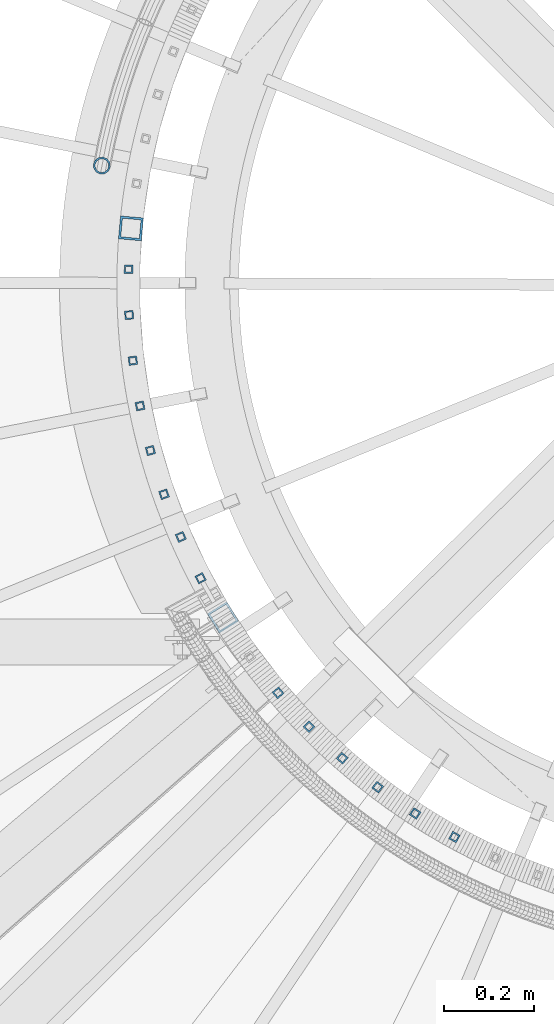
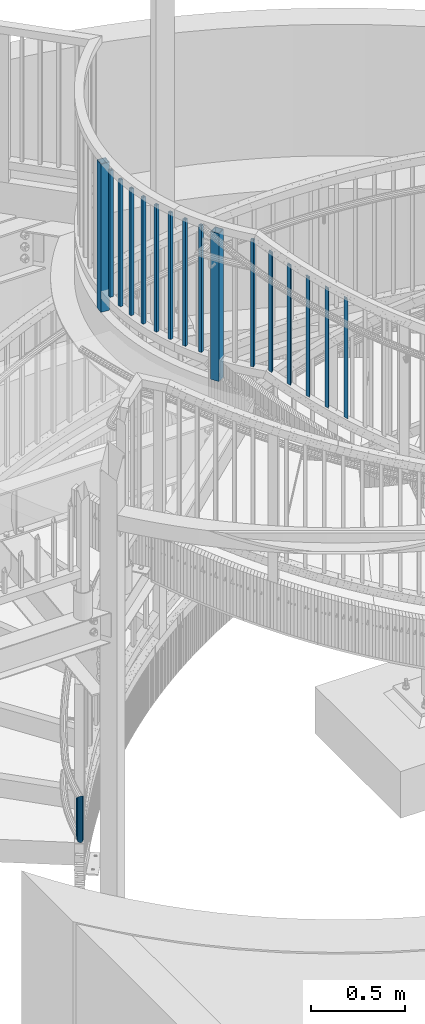
# One storey, part 258 of 975: 17 columns.
"""IFC2X3 building model written with IfcOpenShell, lengths in millimetres."""

from ifc_helpers import new_model, si_unit, frame, origin_with_axes, place, context, subcontext, project, spatial, faceted_brep, material, type_object, element, save


model = new_model("IFC2X3")

# Units and contexts
model_context = context("Model", 3, precision=1e-05, world=origin_with_axes())
body_context = subcontext(model_context, "Body", "Model", "MODEL_VIEW")
ifc_project = project(units=[si_unit("LENGTHUNIT", "METRE", prefix="MILLI"), si_unit("AREAUNIT", "SQUARE_METRE"), si_unit("VOLUMEUNIT", "CUBIC_METRE"), si_unit("MASSUNIT", "GRAM", prefix="KILO"), si_unit("TIMEUNIT", "SECOND"), si_unit("PLANEANGLEUNIT", "RADIAN"), si_unit("SOLIDANGLEUNIT", "STERADIAN"), si_unit("THERMODYNAMICTEMPERATUREUNIT", "DEGREE_CELSIUS"), si_unit("LUMINOUSINTENSITYUNIT", "LUMEN")], contexts=[model_context])

# Site, building, storey
site_placement = place(None, origin_with_axes())
site = spatial("IfcSite", under=ifc_project, at=site_placement, CompositionType="ELEMENT")
building_placement = place(site_placement, origin_with_axes())
building = spatial("IfcBuilding", under=site, at=building_placement, Name="Undefined", CompositionType="ELEMENT")
storey_placement = place(building_placement, origin_with_axes())
storey = spatial("IfcBuildingStorey", under=building, at=storey_placement, Name="Undefined", CompositionType="ELEMENT", Elevation=0.0)

# Columns
ifc_material = material()
column_type_1 = type_object("IfcColumnType", Name="HSS3/4X3/4X.120_TUBES", PredefinedType="NOTDEFINED")
for number, where, z_axis, x_axis, name in (
    (1, (33338.0118651315, 3439.09067871105, 4279.9), (-0.999675195412586, 0.0254853620105182, 0.0), (0.0, 0.0, 1.0), "PICKET"),
    (2, (33339.116408192, 3337.53503253503, 4279.9), (-0.998884410589074, -0.0472221799805738, 0.0), (0.0, 0.0, 1.0), "PICKET"),
    (3, (33347.5974477952, 3236.3281095807, 4279.9), (-0.992812511867641, -0.119680057984045, 0.0), (0.0, 0.0, 1.0), "PICKET"),
    (4, (33363.4101445628, 3136.00499207486, 4279.9), (-0.981491601442438, -0.191505186086326, 0.0), (0.0, 0.0, 1.0), "PICKET"),
    (5, (33386.4708966174, 3037.09608953945, 4279.9), (-0.964981533340402, -0.262317823092534, 0.0), (0.0, 0.0, 1.0), "PICKET"),
    (6, (33416.6577814516, 2940.12433452441, 4279.9), (-0.943369596226937, -0.331743583079804, 0.0), (0.0, 0.0, 1.0), "PICKET"),
    (7, (33453.8112006605, 2845.60241787445, 4279.9), (-0.916770052714921, -0.399415410875797, 0.0), (0.0, 0.0, 1.0), "PICKET"),
    (8, (33497.7347236588, 2754.03007809531, 4279.9), (-0.885323534790213, -0.46497552488982, 0.0), (0.0, 0.0, 1.0), "PICKET"),
    (9, (33669.5281021066, 2499.83083556219, 4279.9), (-0.762453802431629, -0.647042656366294, 0.0), (0.0, 0.0, 1.0), "PICKET"),
):
    element("IfcColumn", number, at=place(storey_placement, frame(where, z_axis=z_axis, x_axis=x_axis)), inside=storey, type_object=column_type_1, material=ifc_material, Name=name, ObjectType="HSS3/4X3/4X.120_TUBES", context=body_context, shape_type="Brep", body=[
        faceted_brep([(0.0, 6.34999999998763, -6.34999999998763), (0.0, -6.35000000000582, -6.34999999998763), (825.49997943247, -6.35000000000582, -6.34999999998763), (825.49997943247, 6.34999999998763, -6.34999999998763), (0.0, -6.34999999998763, 6.34999999998763), (825.49997943247, -6.34999999998763, 6.34999999998763), (0.0, 6.35000000000946, 6.34999999998763), (825.49997943247, 6.35000000000946, 6.34999999998763), (0.0, 9.52499999997963, -9.52499999997963), (0.0, 9.52500000000873, 9.5249999999869), (825.49997943247, 9.52500000000873, 9.5249999999869), (825.49997943247, 9.52499999997963, -9.52499999997963), (0.0, -9.52499999997963, 9.52499999998327), (825.49997943247, -9.52499999997963, 9.52499999998327), (0.0, -9.52500000000873, -9.5249999999869), (825.49997943247, -9.52500000000873, -9.5249999999869)], [[[0, 1, 2, 3]], [[1, 4, 5, 2]], [[4, 6, 7, 5]], [[6, 0, 3, 7]], [[8, 9, 10, 11]], [[9, 12, 13, 10]], [[12, 14, 15, 13]], [[14, 8, 11, 15]], [[13, 15, 11, 10], [5, 7, 3, 2]], [[14, 12, 9, 8], [6, 4, 1, 0]]]),
    ])
for number, where, z_axis, x_axis, name in (
    (10, (33738.0146394789, 2424.8350790669, 4191.955686045), (-0.71342169087057, -0.700734964872866, 0.0), (0.0, 0.0, 1.0), "PICKET"),
    (11, (33811.7696069116, 2355.01406451793, 4125.280686045), (-0.660617710250523, -0.750722479284692, 0.0), (0.0, 0.0, 1.0), "PICKET"),
    (12, (33890.4030610031, 2290.73693646062, 4058.605686045), (-0.604321034827168, -0.796740915772135, 0.0), (0.0, 0.0, 1.0), "PICKET"),
    (13, (33973.4992657341, 2232.34352884534, 3992.724436045), (-0.544829307083477, -0.838546973128481, 0.0), (0.0, 0.0, 1.0), "PICKET"),
    (14, (34060.6188904695, 2180.14256832157, 3926.049436045), (-0.482457061020897, -0.875919622037935, 0.0), (0.0, 0.0, 1.0), "PICKET"),
):
    element("IfcColumn", number, at=place(storey_placement, frame(where, z_axis=z_axis, x_axis=x_axis)), inside=storey, type_object=column_type_1, material=ifc_material, Name=name, ObjectType="HSS3/4X3/4X.120_TUBES", context=body_context, shape_type="Brep", body=[
        faceted_brep([(81.3030822565961, 6.34999999999491, -6.34999999997672), (73.0243810963957, -6.34999999999854, -6.35000000000582), (849.31820965341, -6.34999999999854, -6.35000000000582), (857.556470281766, 6.34999999999491, -6.34999999997672), (73.0243810963952, -6.34999999999127, 6.34999999998399), (849.318209653409, -6.34999999999127, 6.34999999998399), (81.3030822565956, 6.35000000000218, 6.34999999999854), (857.556470281765, 6.35000000000218, 6.34999999999854), (83.3727575466464, 9.52499999999054, -9.52499999997235), (83.3727575466455, 9.52500000000509, 9.52500000000146), (859.616035438854, 9.52500000000509, 9.52500000000146), (859.616035438854, 9.52499999999054, -9.52499999997235), (70.9547058063449, -9.5249999999869, 9.52499999997235), (847.25864449632, -9.5249999999869, 9.52499999997235), (70.9547058063458, -9.52500000000146, -9.52499999999418), (847.258644496321, -9.52500000000146, -9.52499999999418)], [[[0, 1, 2, 3]], [[1, 4, 5, 2]], [[4, 6, 7, 5]], [[6, 0, 3, 7]], [[8, 9, 10, 11]], [[9, 12, 13, 10]], [[12, 14, 15, 13]], [[14, 8, 11, 15]], [[13, 15, 11, 10], [5, 7, 3, 2]], [[14, 12, 9, 8], [6, 4, 1, 0]]]),
    ])
column_type_2 = type_object("IfcColumnType", Name="HSS2X2X.188_TUBES", PredefinedType="NOTDEFINED")
for number, where, z_axis, x_axis, name in (
    (15, (33343.2053867211, 3529.72810575534, 4140.2), (-0.995915974724204, 0.0902849449749974, 0.0), (0.0, 0.0, 1.0), "HANDRAIL"),
    (16, (33547.4569280127, 2667.02838416945, 4140.2), (-0.8497086989124, -0.527252431945644, 0.0), (0.0, 0.0, 1.0), "HANDRAIL"),
):
    element("IfcColumn", number, at=place(storey_placement, frame(where, z_axis=z_axis, x_axis=x_axis)), inside=storey, type_object=column_type_2, material=ifc_material, Name=name, ObjectType="HSS2X2X.188_TUBES", context=body_context, shape_type="Brep", body=[
        faceted_brep([(0.0, 20.6374999999753, -20.6375000000298), (0.0, -20.6375000000153, -20.6375000000153), (965.200000000001, -20.6374999999025, -20.6375000000808), (965.200000000001, 20.637500000008, -20.637500000008), (0.0, -20.6374999999825, 20.6375000000335), (965.200000000001, -20.6375000000007, 20.6375000000116), (0.0, 20.6375000000116, 20.6375000000189), (965.200000000001, 20.6374999999061, 20.6375000000844), (0.0, 25.3999999999724, -25.4000000000342), (0.0, 25.400000000016, 25.4000000000196), (965.200000000001, 25.399999999885, 25.400000000107), (965.200000000001, 25.4000000000124, -25.4000000000124), (0.0, -25.399999999976, 25.4000000000378), (965.200000000001, -25.4000000000015, 25.4000000000124), (0.0, -25.400000000016, -25.4000000000196), (965.200000000001, -25.3999999998778, -25.4000000001033)], [[[0, 1, 2, 3]], [[1, 4, 5, 2]], [[4, 6, 7, 5]], [[6, 0, 3, 7]], [[8, 9, 10, 11]], [[9, 12, 13, 10]], [[12, 14, 15, 13]], [[14, 8, 11, 15]], [[13, 15, 11, 10], [5, 7, 3, 2]], [[14, 12, 9, 8], [6, 4, 1, 0]]]),
    ])
column_type_3 = type_object("IfcColumnType", PredefinedType="NOTDEFINED")
column_placement = place(storey_placement, frame((33278.7955524752, 3668.84646025861, 609.6), z_axis=(0.16657944603268, 0.986028036193417, 0.0), x_axis=(0.0, 0.0, 1.0)))
element("IfcColumn", 17, at=column_placement, inside=storey, type_object=column_type_3, material=ifc_material, Name="HANDRAIL", context=body_context, shape_type="Brep", body=[
    faceted_brep([(18.916988254354, -15.3669999999365, 1.09139364212751e-11), (26.61830844902, -13.3082123798886, 7.68350000001374), (278.182504532853, -13.3082123798886, 7.68350000001374), (285.883950497071, -15.3669999999365, 1.09139364212751e-11), (32.2917065065848, -7.68349999994098, 13.3082123799686), (272.508762868242, -7.68349999994098, 13.3082123799686), (34.4169999991835, 4.00177668780088e-11, 15.3670000000093), (270.383000000335, 4.00177668780088e-11, 15.3670000000093), (32.4247182517954, 7.6835000000101, 13.3082123799577), (272.374812372886, 7.6835000000101, 13.3082123799577), (26.8486915497282, 13.3082123799359, 7.68349999999737), (277.950495469197, 13.3082123799359, 7.68349999999737), (19.1830117447753, 15.3669999999511, -1.09139364212751e-11), (285.61604950636, 15.3669999999511, -1.09139364212751e-11), (11.4816915501094, 13.3082123799031, -7.68350000001374), (293.317495470578, 13.3082123799031, -7.68350000001374), (5.80829349254464, 7.68349999994825, -13.3082123799686), (298.991237135189, 7.68349999994825, -13.3082123799686), (3.68299999994588, -2.5465851649642e-11, -15.3670000000075), (301.117000003096, -2.5465851649642e-11, -15.3670000000075), (5.675281747334, -7.68349999999555, -13.3082123799577), (299.125187630545, -7.68349999999555, -13.3082123799577), (11.2513084494011, -13.3082123799213, -7.68349999999555), (293.549504534234, -13.3082123799213, -7.68349999999555), (18.8851094063283, -19.0499999999265, 1.2732925824821e-11), (9.3822005572132, -16.4977839420571, -9.52499999999418), (295.418807273432, -16.4977839420571, -9.52499999999418), (285.916054334801, -19.0499999999265, 1.2732925824821e-11), (2.46977076126211, -9.52500000000146, -16.4977839420972), (302.330811111834, -9.52500000000146, -16.4977839420972), (-3.63797880709171e-12, 3.63797880709171e-12, -19.0500000000002), (304.800000003427, -4.00177668780088e-11, -19.0500000000102), (2.63466135449846, 9.52499999993233, -16.4977839421099), (302.164756778749, 9.52499999993233, -16.4977839421099), (9.66779944238863, 16.4977839420171, -9.52500000001601), (295.131192731711, 16.4977839420171, -9.52500000001601), (19.214890592801, 19.0499999999411, -1.2732925824821e-11), (285.58394566863, 19.0499999999411, -1.2732925824821e-11), (28.7177994419161, 16.4977839420644, 9.524999999996), (276.081192729999, 16.4977839420644, 9.524999999996), (35.6302292378672, 9.52500000000873, 16.4977839420972), (269.169188891597, 9.52500000000873, 16.4977839420972), (38.0999999990921, 5.45696821063757e-11, 19.050000000012), (266.700000000004, 5.45696821063757e-11, 19.050000000012), (35.4653386446308, -9.52499999992506, 16.4977839421099), (269.335243224682, -9.52499999992506, 16.4977839421099), (28.4322005567407, -16.4977839420098, 9.52500000001601), (276.36880727172, -16.4977839420098, 9.52500000001601)], [[[0, 1, 2, 3]], [[1, 4, 5, 2]], [[4, 6, 7, 5]], [[6, 8, 9, 7]], [[8, 10, 11, 9]], [[10, 12, 13, 11]], [[12, 14, 15, 13]], [[14, 16, 17, 15]], [[16, 18, 19, 17]], [[18, 20, 21, 19]], [[20, 22, 23, 21]], [[22, 0, 3, 23]], [[24, 25, 26, 27]], [[25, 28, 29, 26]], [[28, 30, 31, 29]], [[30, 32, 33, 31]], [[32, 34, 35, 33]], [[34, 36, 37, 35]], [[36, 38, 39, 37]], [[38, 40, 41, 39]], [[40, 42, 43, 41]], [[42, 44, 45, 43]], [[44, 46, 47, 45]], [[46, 24, 27, 47]], [[29, 31, 33, 35, 37, 39, 41, 43, 45, 47, 27, 26], [5, 7, 9, 11, 13, 15, 17, 19, 21, 23, 3, 2]], [[46, 44, 42, 40, 38, 36, 34, 32, 30, 28, 25, 24], [22, 20, 18, 16, 14, 12, 10, 8, 6, 4, 1, 0]]]),
])

save(model, "model.ifc")
